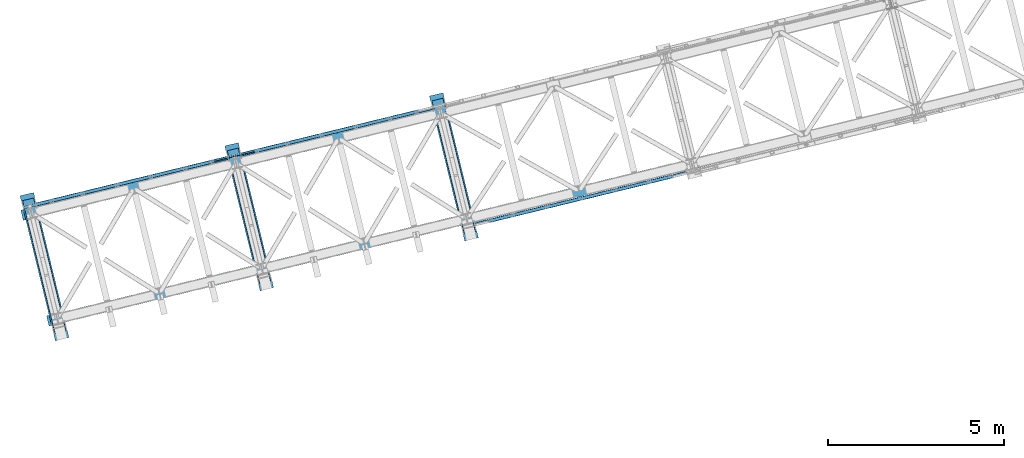
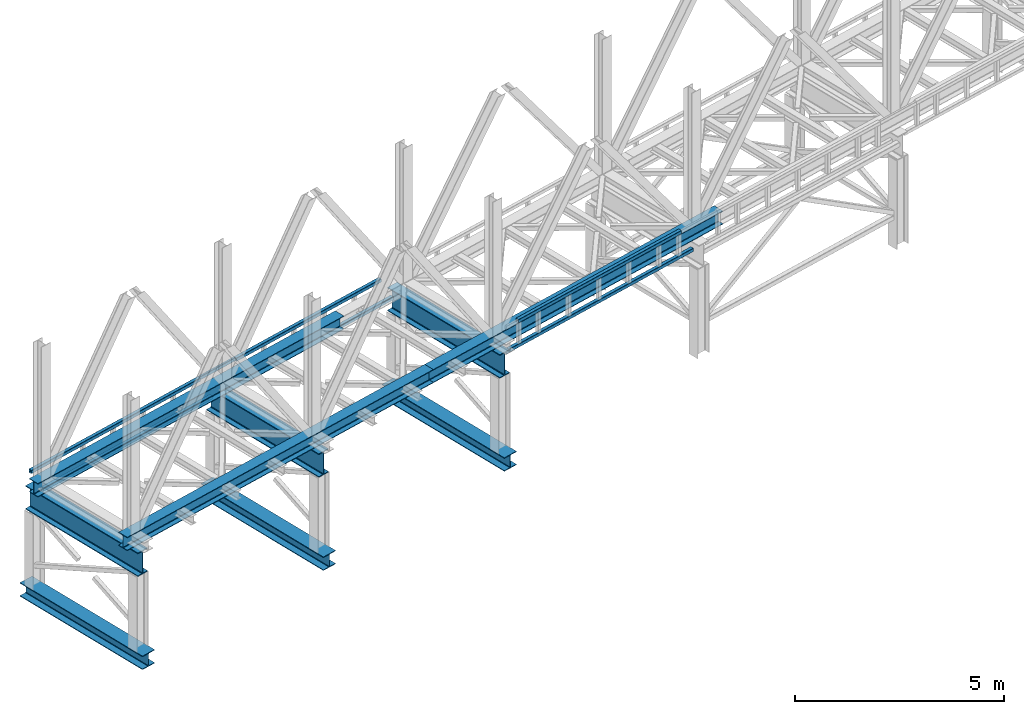
# One storey, part 15 of 93: 16 beams.
"""IFC4 building model written with IfcOpenShell, lengths in millimetres."""

from ifc_helpers import new_model, entity, si_unit, converted_unit, derived_unit, direction, frame, origin, place, context, subcontext, project, spatial, indexed_curve, outline, extrude, material, type_object, element, save


model = new_model("IFC4")

# Units and contexts
model_context = context("Model", 3, precision=0.01, world=origin(), true_north=direction((6.12303176911189e-17, 1.0)))
plan_context = context("Plan", 3, precision=0.01, world=origin(), true_north=direction((6.12303176911189e-17, 1.0)))
body_context = subcontext(model_context, "Body", "Model", "MODEL_VIEW")
ifc_project = project(units=[si_unit("LENGTHUNIT", "METRE", prefix="MILLI"), si_unit("AREAUNIT", "SQUARE_METRE"), si_unit("VOLUMEUNIT", "CUBIC_METRE"), converted_unit("PLANEANGLEUNIT", "DEGREE", entity("IfcRatioMeasure", 0.0174532925199433), si_unit("PLANEANGLEUNIT", "RADIAN"), dimensions=[0, 0, 0, 0, 0, 0, 0]), si_unit("MASSUNIT", "GRAM", prefix="KILO"), derived_unit("MASSDENSITYUNIT", [(si_unit("MASSUNIT", "GRAM", prefix="KILO"), 1), (si_unit("LENGTHUNIT", "METRE"), -3)]), derived_unit("MOMENTOFINERTIAUNIT", [(si_unit("LENGTHUNIT", "METRE"), 4)]), si_unit("TIMEUNIT", "SECOND"), si_unit("FREQUENCYUNIT", "HERTZ"), si_unit("THERMODYNAMICTEMPERATUREUNIT", "DEGREE_CELSIUS"), derived_unit("THERMALTRANSMITTANCEUNIT", [(si_unit("MASSUNIT", "GRAM", prefix="KILO"), 1), (si_unit("THERMODYNAMICTEMPERATUREUNIT", "KELVIN"), -1), (si_unit("TIMEUNIT", "SECOND"), -3)]), derived_unit("VOLUMETRICFLOWRATEUNIT", [(si_unit("LENGTHUNIT", "METRE"), 3), (si_unit("TIMEUNIT", "SECOND"), -1)]), derived_unit("MASSFLOWRATEUNIT", [(si_unit("MASSUNIT", "GRAM", prefix="KILO"), 1), (si_unit("TIMEUNIT", "SECOND"), -1)]), derived_unit("ROTATIONALFREQUENCYUNIT", [(si_unit("TIMEUNIT", "SECOND"), -1)]), si_unit("ELECTRICCURRENTUNIT", "AMPERE"), si_unit("ELECTRICVOLTAGEUNIT", "VOLT"), si_unit("POWERUNIT", "WATT"), si_unit("FORCEUNIT", "NEWTON", prefix="KILO"), si_unit("ILLUMINANCEUNIT", "LUX"), si_unit("LUMINOUSFLUXUNIT", "LUMEN"), si_unit("LUMINOUSINTENSITYUNIT", "CANDELA"), derived_unit("USERDEFINED", [(si_unit("MASSUNIT", "GRAM", prefix="KILO"), -1), (si_unit("LENGTHUNIT", "METRE"), -2), (si_unit("TIMEUNIT", "SECOND"), 3), (si_unit("LUMINOUSFLUXUNIT", "LUMEN"), 1)]), derived_unit("LINEARVELOCITYUNIT", [(si_unit("LENGTHUNIT", "METRE"), 1), (si_unit("TIMEUNIT", "SECOND"), -1)]), si_unit("PRESSUREUNIT", "PASCAL"), derived_unit("USERDEFINED", [(si_unit("LENGTHUNIT", "METRE"), -2), (si_unit("MASSUNIT", "GRAM", prefix="KILO"), 1), (si_unit("TIMEUNIT", "SECOND"), -2)]), derived_unit("LINEARFORCEUNIT", [(si_unit("MASSUNIT", "GRAM", prefix="KILO"), 1), (si_unit("LENGTHUNIT", "METRE"), 1), (si_unit("TIMEUNIT", "SECOND"), -2), (si_unit("LENGTHUNIT", "METRE"), -1)]), derived_unit("PLANARFORCEUNIT", [(si_unit("MASSUNIT", "GRAM", prefix="KILO"), 1), (si_unit("LENGTHUNIT", "METRE"), 1), (si_unit("TIMEUNIT", "SECOND"), -2), (si_unit("LENGTHUNIT", "METRE"), -2)])], contexts=[model_context, plan_context])

# Site, building, storey
site_placement = place(None, origin())
site = spatial("IfcSite", under=ifc_project, at=site_placement, CompositionType="ELEMENT")
building_placement = place(site_placement, origin())
building = spatial("IfcBuilding", under=site, at=building_placement, CompositionType="ELEMENT")
storey_placement = place(building_placement, frame((0.0, 0.0, 15900.0)))
storey = spatial("IfcBuildingStorey", under=building, at=storey_placement, CompositionType="ELEMENT", Elevation=15900.0)

# Beams
ifc_material = material(Name="Metal painted (White)")
beam_type = type_object("IfcBeamType", PredefinedType="BEAM")
beam_1_placement = place(storey_placement, origin())
element("IfcBeam", 1, at=beam_1_placement, inside=storey, type_object=beam_type, material=ifc_material, ObjectType="Steel Beam", PredefinedType="BEAM", context=body_context, shape_type="SweptSolid", body=[
    extrude(outline(indexed_curve([(-199.999999999998, -200.000000000009), (-180.0, -200.000000000009), (-180.0, -28.500000000011), (-178.325349715245, -20.0809644879738), (-173.556349186101, -12.9436508139005), (-166.419035512029, -8.17465028475953), (-157.999999999999, -6.50000000000747), (158.000000000001, -6.50000000000747), (166.419035512033, -8.17465028475953), (173.556349186107, -12.9436508139005), (178.325349715251, -20.0809644879738), (180.000000000002, -28.500000000011), (180.000000000002, -200.000000000009), (200.0, -200.000000000009), (200.0, 199.999999999991), (180.000000000002, 199.999999999991), (180.000000000002, 28.4999999999932), (178.325349715247, 20.0809644879561), (173.556349186107, 12.9436508138827), (166.419035512033, 8.1746502847418), (158.000000000001, 6.49999999998974), (-157.999999999999, 6.49999999999861), (-166.419035512029, 8.17465028475066), (-173.556349186101, 12.9436508139005), (-178.325349715245, 20.080964487965), (-179.999999999998, 28.5000000000021), (-180.0, 199.999999999991), (-199.999999999998, 199.999999999991), (-199.999999999998, -200.000000000009)], self_intersect=False)), frame((-60133.5481539839, 2325.81989631517, 198.0), z_axis=(-0.236826092990339, 0.971552058141473, 0.0), x_axis=(0.0, 0.0, 1.0)), (0.0, 0.0, 1.0), 4250.00000000001),
])
beam_2_placement = place(storey_placement, origin())
element("IfcBeam", 2, at=beam_2_placement, inside=storey, type_object=beam_type, material=ifc_material, ObjectType="Steel Beam", PredefinedType="BEAM", context=body_context, shape_type="SweptSolid", body=[
    extrude(outline(indexed_curve([(-345.500000000002, -160.000000000002), (-322.5, -160.000000000002), (-322.5, -37.4999999999994), (-320.216385975338, -26.0194970290429), (-313.713203435595, -16.2867965644056), (-303.980502970953, -9.78361402465815), (-292.499999999998, -7.49999999999633), (292.500000000001, -7.49999999999633), (303.980502970953, -9.78361402465815), (313.713203435597, -16.2867965644056), (320.21638597534, -26.0194970290429), (322.5, -37.4999999999994), (322.5, -160.000000000002), (345.499999999997, -160.000000000002), (345.499999999997, 160.000000000002), (322.5, 160.000000000002), (322.5, 37.4999999999994), (320.21638597534, 26.0194970290429), (313.713203435597, 16.2867965644056), (303.980502970953, 9.78361402465815), (292.500000000001, 7.49999999999633), (-292.499999999998, 7.50000000000526), (-303.980502970953, 9.78361402466708), (-313.713203435595, 16.2867965644056), (-320.216385975338, 26.0194970290429), (-322.5, 37.4999999999994), (-322.5, 160.000000000002), (-345.500000000002, 160.000000000002), (-345.500000000002, -160.000000000002)], self_intersect=False)), frame((-60180.913372582, 2520.13030794346, 2947.5), z_axis=(-0.236826092990334, 0.971552058141474, 0.0), x_axis=(0.0, 0.0, 1.0)), (0.0, 0.0, 1.0), 3899.99999999999),
])
beam_3_placement = place(storey_placement, origin())
element("IfcBeam", 3, at=beam_3_placement, inside=storey, type_object=beam_type, material=ifc_material, ObjectType="Steel Beam", PredefinedType="BEAM", context=body_context, shape_type="SweptSolid", body=[
    extrude(outline(indexed_curve([(-199.999999999998, -200.0), (-180.0, -200.0), (-180.0, -28.5000000000021), (-178.325349715245, -20.080964487965), (-173.556349186101, -12.9436508138917), (-166.419035512029, -8.17465028475066), (-157.999999999999, -6.49999999999867), (158.000000000001, -6.49999999999867), (166.419035512033, -8.17465028475066), (173.556349186107, -12.9436508138917), (178.325349715251, -20.080964487965), (180.000000000002, -28.5000000000021), (180.000000000002, -200.0), (200.0, -200.0), (200.0, 200.0), (180.000000000002, 200.0), (180.000000000002, 28.5000000000021), (178.325349715247, 20.080964487965), (173.556349186107, 12.9436508138917), (166.419035512033, 8.17465028475066), (158.000000000001, 6.49999999999854), (-157.999999999999, 6.50000000000747), (-166.419035512029, 8.17465028475959), (-173.556349186101, 12.9436508139094), (-178.325349715245, 20.0809644879738), (-179.999999999998, 28.500000000011), (-180.0, 200.0), (-199.999999999998, 200.0), (-199.999999999998, -200.0)], self_intersect=False)), frame((-54304.2358051351, 3746.77645425719, 198.0), z_axis=(-0.236826092990342, 0.971552058141472, 0.0), x_axis=(0.0, 0.0, 1.0)), (0.0, 0.0, 1.0), 4250.0),
])
beam_4_placement = place(storey_placement, origin())
element("IfcBeam", 4, at=beam_4_placement, inside=storey, type_object=beam_type, material=ifc_material, ObjectType="Steel Beam", PredefinedType="BEAM", context=body_context, shape_type="SweptSolid", body=[
    extrude(outline(indexed_curve([(-345.500000000002, -159.999999999993), (-322.5, -159.999999999993), (-322.5, -37.4999999999906), (-320.216385975338, -26.0194970290341), (-313.713203435595, -16.2867965643968), (-303.980502970953, -9.78361402464935), (-292.499999999998, -7.4999999999874), (292.500000000001, -7.4999999999874), (303.980502970953, -9.78361402464935), (313.713203435597, -16.2867965643968), (320.21638597534, -26.0194970290341), (322.5, -37.4999999999906), (322.5, -159.999999999993), (345.499999999997, -159.999999999993), (345.499999999997, 160.000000000011), (322.5, 160.000000000011), (322.5, 37.5000000000083), (320.21638597534, 26.0194970290519), (313.713203435597, 16.2867965644145), (303.980502970953, 9.78361402466708), (292.500000000001, 7.50000000000526), (-292.499999999998, 7.50000000001406), (-303.980502970953, 9.78361402466708), (-313.713203435595, 16.2867965644145), (-320.216385975338, 26.0194970290519), (-322.5, 37.5000000000083), (-322.5, 160.000000000011), (-345.500000000002, 160.000000000011), (-345.500000000002, -159.999999999993)], self_intersect=False)), frame((-54351.6010237331, 3941.08686588548, 2947.5), z_axis=(-0.236826092990334, 0.971552058141474, 0.0), x_axis=(0.0, 0.0, 1.0)), (0.0, 0.0, 1.0), 3899.99999999999),
])
beam_5_placement = place(storey_placement, origin())
element("IfcBeam", 5, at=beam_5_placement, inside=storey, type_object=beam_type, material=ifc_material, ObjectType="Steel Beam", PredefinedType="BEAM", context=body_context, shape_type="SweptSolid", body=[
    extrude(outline(indexed_curve([(-199.999999999998, -199.999999999992), (-180.0, -199.999999999992), (-180.0, -28.4999999999933), (-178.325349715245, -20.0809644879649), (-173.556349186101, -12.9436508138917), (-166.419035512029, -8.17465028474173), (-157.999999999999, -6.49999999999867), (158.000000000001, -6.49999999999867), (166.419035512033, -8.17465028474173), (173.556349186107, -12.9436508138917), (178.325349715251, -20.0809644879649), (180.000000000002, -28.4999999999933), (180.000000000002, -199.999999999992), (200.0, -199.999999999992), (200.0, 200.000000000009), (180.000000000002, 200.000000000009), (180.000000000002, 28.5000000000022), (178.325349715247, 20.0809644879738), (173.556349186107, 12.9436508139006), (166.419035512033, 8.17465028475959), (158.000000000001, 6.5000000000076), (-157.999999999999, 6.50000000001628), (-166.419035512029, 8.17465028476852), (-173.556349186101, 12.9436508139095), (-178.325349715245, 20.0809644879828), (-179.999999999998, 28.5000000000198), (-180.0, 200.000000000009), (-199.999999999998, 200.000000000009), (-199.999999999998, -199.999999999992)], self_intersect=False)), frame((-48474.9234562862, 5167.73301219921, 198.0), z_axis=(-0.236826092990345, 0.971552058141471, 0.0), x_axis=(0.0, 0.0, 1.0)), (0.0, 0.0, 1.0), 4250.00000000001),
])
beam_6_placement = place(storey_placement, origin())
element("IfcBeam", 6, at=beam_6_placement, inside=storey, type_object=beam_type, material=ifc_material, ObjectType="Steel Beam", PredefinedType="BEAM", context=body_context, shape_type="SweptSolid", body=[
    extrude(outline(indexed_curve([(-345.500000000002, -160.00000000001), (-322.5, -160.00000000001), (-322.5, -37.5000000000082), (-320.216385975338, -26.0194970290607), (-313.713203435595, -16.2867965644145), (-303.980502970953, -9.78361402467601), (-292.499999999998, -7.50000000000526), (292.500000000001, -7.50000000000526), (303.980502970953, -9.78361402467601), (313.713203435597, -16.2867965644145), (320.21638597534, -26.0194970290607), (322.5, -37.5000000000082), (322.5, -160.00000000001), (345.499999999997, -160.00000000001), (345.499999999997, 159.999999999993), (322.5, 159.999999999993), (322.5, 37.4999999999906), (320.21638597534, 26.0194970290341), (313.713203435597, 16.2867965643967), (303.980502970953, 9.78361402464922), (292.500000000001, 7.4999999999874), (-292.499999999998, 7.49999999999633), (-303.980502970953, 9.78361402465815), (-313.713203435595, 16.2867965643967), (-320.216385975338, 26.0194970290431), (-322.5, 37.4999999999906), (-322.5, 159.999999999993), (-345.500000000002, 159.999999999993), (-345.500000000002, -160.00000000001)], self_intersect=False)), frame((-48522.2886748843, 5362.0434238275, 2947.5), z_axis=(-0.23682609299033, 0.971552058141475, 0.0), x_axis=(0.0, 0.0, 1.0)), (0.0, 0.0, 1.0), 3899.99999999999),
])
beam_7_placement = place(storey_placement, origin())
element("IfcBeam", 7, at=beam_7_placement, inside=storey, type_object=beam_type, material=ifc_material, ObjectType="Steel Beam", PredefinedType="BEAM", context=body_context, shape_type="SweptSolid", body=[
    extrude(outline(indexed_curve([(-195.999999999999, -150.000000000005), (-179.999999999996, -150.000000000005), (-179.999999999996, -27.7500000000052), (-178.325349715245, -19.3309644879708), (-173.556349186101, -12.1936508139001), (-166.419035512029, -7.42465028475701), (-157.999999999997, -5.75000000000373), (158.000000000005, -5.75000000000373), (166.419035512033, -7.42465028475701), (173.556349186107, -12.1936508139001), (178.325349715251, -19.3309644879708), (180.0, -27.7500000000052), (180.0, -150.000000000005), (196.000000000005, -150.000000000005), (196.000000000005, 149.999999999996), (180.0, 149.999999999996), (180.0, 27.7499999999967), (178.325349715251, 19.3309644879629), (173.556349186107, 12.1936508138912), (166.419035512033, 7.42465028474807), (158.000000000005, 5.74999999999531), (-157.999999999997, 5.74999999999689), (-166.419035512029, 7.42465028474965), (-173.556349186101, 12.1936508138933), (-178.325349715245, 19.3309644879639), (-179.999999999996, 27.7499999999973), (-179.999999999996, 149.999999999999), (-195.999999999999, 149.999999999996), (-195.999999999999, -150.000000000005)], self_intersect=False)), frame((-60542.820625767, 2843.62395562771, 3489.0), z_axis=(0.971552058141477, 0.236826092990323, 0.0), x_axis=(0.0, 0.0, 1.0)), (0.0, 0.0, 1.0), 10150.0),
])
beam_8_placement = place(storey_placement, origin())
element("IfcBeam", 8, at=beam_8_placement, inside=storey, type_object=beam_type, material=ifc_material, ObjectType="Steel Beam", PredefinedType="BEAM", context=body_context, shape_type="SweptSolid", body=[
    extrude(outline(indexed_curve([(-195.999999999999, -150.000000000001), (-179.999999999996, -150.000000000001), (-179.999999999996, -27.750000000002), (-178.325349715245, -19.330964487966), (-173.556349186101, -12.1936508138954), (-166.419035512029, -7.4246502847528), (-157.999999999997, -5.75000000000005), (158.000000000005, -5.75000000000005), (166.419035512033, -7.4246502847528), (173.556349186107, -12.1936508138954), (178.325349715251, -19.330964487966), (180.0, -27.750000000002), (180.0, -150.000000000001), (196.000000000005, -150.000000000001), (196.000000000005, 150.000000000001), (180.0, 150.000000000001), (180.0, 27.750000000002), (178.325349715251, 19.330964487966), (173.556349186107, 12.1936508138954), (166.419035512033, 7.42465028475175), (158.000000000005, 5.75000000000005), (-157.999999999997, 5.75000000000005), (-166.419035512029, 7.4246502847528), (-173.556349186101, 12.1936508138965), (-178.325349715245, 19.3309644879681), (-179.999999999996, 27.750000000002), (-179.999999999996, 150.000000000001), (-195.999999999999, 150.000000000001), (-195.999999999999, -150.000000000001)], self_intersect=False)), frame((-50681.5672356311, 5247.40879947962, 3489.0), z_axis=(0.971552058141476, 0.236826092990324, 0.0), x_axis=(0.0, 0.0, 1.0)), (0.0, 0.0, 1.0), 9600.0),
])
beam_9_placement = place(storey_placement, origin())
element("IfcBeam", 9, at=beam_9_placement, inside=storey, type_object=beam_type, material=ifc_material, ObjectType="Steel Beam", PredefinedType="BEAM", context=body_context, shape_type="SweptSolid", body=[
    extrude(outline(indexed_curve([(-195.999999999999, -150.0), (-179.999999999996, -150.0), (-179.999999999996, -27.7499999999988), (-178.325349715245, -19.330964487965), (-173.556349186101, -12.1936508138944), (-166.419035512029, -7.4246502847507), (-157.999999999997, -5.74999999999794), (158.000000000005, -5.74999999999794), (166.419035512033, -7.4246502847507), (173.556349186107, -12.1936508138944), (178.325349715251, -19.330964487965), (180.0, -27.7499999999988), (180.0, -150.0), (196.000000000005, -150.0), (196.000000000005, 150.000000000003), (180.0, 150.000000000003), (180.0, 27.7500000000031), (178.325349715251, 19.3309644879681), (173.556349186107, 12.1936508138986), (166.419035512033, 7.42465028475491), (158.000000000005, 5.75000000000215), (-157.999999999997, 5.7500000000032), (-166.419035512029, 7.42465028475491), (-173.556349186101, 12.1936508138996), (-178.325349715247, 19.3309644879681), (-179.999999999996, 27.7500000000031), (-179.999999999996, 150.000000000003), (-195.999999999999, 150.000000000003), (-195.999999999999, -150.0)], self_intersect=False)), frame((-61276.981514037, 5855.43533586627, 3489.0), z_axis=(0.971552058141477, 0.23682609299032, 0.0), x_axis=(0.0, 0.0, 1.0)), (0.0, 0.0, 1.0), 10150.0),
])
beam_10_placement = place(storey_placement, origin())
element("IfcBeam", 10, at=beam_10_placement, inside=storey, type_object=beam_type, material=ifc_material, ObjectType="Steel Beam", PredefinedType="BEAM", context=body_context, shape_type="SweptSolid", body=[
    extrude(outline(indexed_curve([(29.4768951153388, -56.8428769007951), (33.3787015556623, -56.8428769007951), (36.9835006656957, -55.3497202197886), (39.7424944585247, -52.5907264269583), (41.2356511395302, -48.9859273169241), (56.8428769008066, 29.4768951153362), (56.8428769008059, 33.3787015556666), (55.3497202197987, 36.9835006656969), (52.5907264269695, 39.7424944585246), (48.9859273169341, 41.2356511395347), (-29.4768951153272, 56.8428769008105), (-33.3787015556515, 56.8428769008063), (-36.9835006656859, 55.3497202197999), (-39.7424944585131, 52.5907264269737), (-41.2356511395192, 48.9859273169308), (-56.8428769007946, -29.4768951153297), (-56.8428769007963, -33.3787015556508), (-55.349720219789, -36.9835006656856), (-52.5907264269576, -39.7424944585136), (-48.9859273169225, -41.2356511395193), (29.4768951153388, -56.8428769007951)], self_intersect=False), holes=[indexed_curve([(-50.9634988887029, -25.5484203233846), (-37.3071763475863, 43.1065493048366), (-35.8140196665766, 46.7113484148699), (-33.0550258737478, 49.4703422077047), (-29.4502267637124, 50.9634988887108), (-25.548420323392, 50.9634988887114), (43.1065493048361, 37.3071763475952), (46.7113484148701, 35.8140196665898), (49.4703422076984, 33.0550258737623), (50.963498888707, 29.4502267637229), (50.9634988887104, 25.5484203234008), (37.3071763475958, -43.1065493048208), (35.8140196665845, -46.7113484148627), (33.0550258737576, -49.4703422076934), (29.4502267637232, -50.9634988886997), (25.5484203234048, -50.9634988887007), (-43.1065493048284, -37.3071763475835), (-46.7113484148604, -35.8140196665785), (-49.4703422076917, -33.0550258737504), (-50.9634988887022, -29.450226763715), (-50.9634988887029, -25.5484203233846)], self_intersect=False)]), frame((-61247.5941200419, 6068.4550088408, 3830.0), z_axis=(0.971552058141251, 0.23682609299125, 0.0), x_axis=(0.232275546020893, -0.95288395777052, -0.195090322015947)), (0.0, 0.0, 1.0), 5595.99999999999),
])
beam_11_placement = place(storey_placement, origin())
element("IfcBeam", 11, at=beam_11_placement, inside=storey, type_object=beam_type, material=ifc_material, ObjectType="Steel Beam", PredefinedType="BEAM", context=body_context, shape_type="SweptSolid", body=[
    extrude(outline(indexed_curve([(29.4768951153018, -56.8428769008144), (33.3787015556258, -56.8428769008144), (36.9835006656596, -55.3497202198119), (39.7424944584905, -52.590726426981), (41.2356511394979, -48.9859273169476), (56.842876900814, 29.4768951153048), (56.8428769008189, 33.3787015556257), (55.3497202198128, 36.9835006656636), (52.590726426984, 39.7424944584929), (48.9859273169497, 41.2356511395006), (-29.4768951153031, 56.8428769008191), (-33.3787015556266, 56.8428769008212), (-36.9835006656618, 55.3497202198168), (-39.7424944584927, 52.5907264269859), (-41.2356511395002, 48.9859273169525), (-56.8428769008193, -29.4768951152993), (-56.8428769008191, -33.3787015556212), (-55.3497202198151, -36.9835006656587), (-52.5907264269859, -39.742494458486), (-48.985927316952, -41.2356511394957), (29.4768951153018, -56.8428769008144)], self_intersect=False), holes=[indexed_curve([(-50.963498888721, -25.5484203233671), (-37.3071763475673, 43.1065493048556), (-35.8140196665578, 46.7113484148885), (-33.0550258737259, 49.4703422077192), (-29.4502267636906, 50.9634988887236), (-25.5484203233702, 50.9634988887221), (43.1065493048524, 37.3071763475682), (46.7113484148847, 35.8140196665609), (49.4703422077155, 33.0550258737312), (50.9634988887216, 29.4502267636933), (50.9634988887187, 25.548420323372), (37.3071763475661, -43.1065493048509), (35.8140196665545, -46.7113484148834), (33.055025873724, -49.4703422077122), (29.4502267636888, -50.9634988887166), (25.5484203233694, -50.9634988887153), (-43.1065493048538, -37.3071763475591), (-46.711348414883, -35.8140196665524), (-49.4703422077128, -33.0550258737229), (-50.9634988887218, -29.4502267636888), (-50.963498888721, -25.5484203233671)], self_intersect=False)]), frame((-60866.7457132505, 6161.29083729302, 3118.0), z_axis=(0.971552058141251, 0.23682609299125, 0.0), x_axis=(-0.232275546020868, 0.952883957770417, 0.195090322016481)), (0.0, 0.0, 1.0), 5603.99999999999),
])
beam_12_placement = place(storey_placement, origin())
element("IfcBeam", 12, at=beam_12_placement, inside=storey, type_object=beam_type, material=ifc_material, ObjectType="Steel Beam", PredefinedType="BEAM", context=body_context, shape_type="SweptSolid", body=[
    extrude(outline(indexed_curve([(29.4768951153008, -56.8428769008142), (33.3787015556247, -56.8428769008142), (36.9835006656585, -55.3497202198117), (39.7424944584895, -52.5907264269808), (41.2356511394969, -48.9859273169474), (56.842876900813, 29.476895115305), (56.8428769008179, 33.3787015556259), (55.3497202198118, 36.9835006656638), (52.590726426983, 39.7424944584932), (48.9859273169487, 41.2356511395008), (-29.4768951153041, 56.8428769008193), (-33.3787015556276, 56.8428769008214), (-36.9835006656628, 55.349720219817), (-39.7424944584938, 52.5907264269861), (-41.2356511395012, 48.9859273169527), (-56.8428769008204, -29.4768951152991), (-56.8428769008201, -33.378701555621), (-55.3497202198161, -36.9835006656585), (-52.5907264269869, -39.7424944584858), (-48.985927316952, -41.2356511394957), (29.4768951153008, -56.8428769008142)], self_intersect=False), holes=[indexed_curve([(-50.9634988887189, -25.5484203233675), (-37.3071763475663, 43.1065493048554), (-35.8140196665568, 46.7113484148883), (-33.0550258737259, 49.4703422077192), (-29.4502267636906, 50.9634988887236), (-25.5484203233702, 50.9634988887221), (43.1065493048514, 37.3071763475684), (46.7113484148847, 35.8140196665609), (49.4703422077155, 33.0550258737312), (50.9634988887226, 29.450226763693), (50.9634988887208, 25.5484203233716), (37.3071763475671, -43.1065493048511), (35.8140196665545, -46.7113484148834), (33.0550258737261, -49.4703422077126), (29.4502267636888, -50.9634988887166), (25.5484203233684, -50.9634988887151), (-43.1065493048518, -37.3071763475595), (-46.711348414883, -35.8140196665524), (-49.4703422077128, -33.0550258737229), (-50.9634988887197, -29.4502267636892), (-50.9634988887189, -25.5484203233675)], self_intersect=False)]), frame((-55033.5471561691, 7583.194699607, 3118.0), z_axis=(0.971552058141251, 0.23682609299125, 0.0), x_axis=(-0.232275546020868, 0.952883957770417, 0.195090322016481)), (0.0, 0.0, 1.0), 5600.00000000001),
])
beam_13_placement = place(storey_placement, origin())
element("IfcBeam", 13, at=beam_13_placement, inside=storey, type_object=beam_type, material=ifc_material, ObjectType="Steel Beam", PredefinedType="BEAM", context=body_context, shape_type="SweptSolid", body=[
    extrude(outline(indexed_curve([(29.4768951153378, -56.8428769007949), (33.3787015556613, -56.8428769007949), (36.9835006656947, -55.3497202197884), (39.7424944585237, -52.5907264269581), (41.2356511395291, -48.9859273169239), (56.8428769008073, 29.4768951153449), (56.8428769008049, 33.3787015556668), (55.3497202197977, 36.9835006656971), (52.5907264269684, 39.7424944585248), (48.9859273169331, 41.2356511395349), (-29.4768951153282, 56.8428769008107), (-33.3787015556525, 56.8428769008065), (-36.983500665687, 55.3497202198001), (-39.7424944585141, 52.5907264269739), (-41.2356511395206, 48.9859273169399), (-56.8428769007957, -29.4768951153295), (-56.8428769007974, -33.3787015556506), (-55.34972021979, -36.9835006656854), (-52.5907264269587, -39.7424944585134), (-48.9859273169235, -41.2356511395191), (29.4768951153378, -56.8428769007949)], self_intersect=False), holes=[indexed_curve([(-50.9634988887029, -25.5484203233846), (-37.3071763475873, 43.1065493048368), (-35.8140196665787, 46.7113484148704), (-33.0550258737499, 49.4703422077051), (-29.4502267637124, 50.9634988887108), (-25.548420323393, 50.9634988887117), (43.1065493048361, 37.3071763475952), (46.711348414866, 35.8140196665906), (49.4703422076974, 33.0550258737625), (50.963498888707, 29.4502267637229), (50.9634988887094, 25.548420323401), (37.3071763475958, -43.1065493048208), (35.8140196665835, -46.7113484148625), (33.0550258737566, -49.4703422076932), (29.4502267637221, -50.9634988886995), (25.5484203234017, -50.9634988887001), (-43.1065493048284, -37.3071763475835), (-46.7113484148614, -35.8140196665783), (-49.4703422076938, -33.05502587375), (-50.9634988887022, -29.450226763715), (-50.9634988887029, -25.5484203233846)], self_intersect=False)]), frame((-54644.9263329125, 7677.92513680314, 3830.0), z_axis=(0.971552058141251, 0.23682609299125, 0.0), x_axis=(0.232275546020893, -0.95288395777052, -0.195090322015947)), (0.0, 0.0, 1.0), 4799.99999999999),
])
beam_14_placement = place(storey_placement, origin())
element("IfcBeam", 14, at=beam_14_placement, inside=storey, type_object=beam_type, material=ifc_material, ObjectType="Steel Beam", PredefinedType="BEAM", context=body_context, shape_type="SweptSolid", body=[
    extrude(outline(indexed_curve([(9.86118950714915, -52.9410704605091), (13.7629959474743, -52.9410704605091), (17.3677950575112, -51.4479137795148), (20.126788850346, -48.6889199866861), (21.6199455313573, -45.0841208766548), (37.2271712928046, 33.3787015555715), (37.2271712928149, 37.2805079958926), (35.7340146118143, 40.8853071059309), (32.97502081899, 43.6443008987647), (29.370221708959, 45.1374575797825), (-9.86118950715515, 52.9410704605059), (-13.7629959474785, 52.9410704605099), (-17.3677950575151, 51.4479137795112), (-20.1267888503512, 48.6889199866871), (-21.6199455313625, 45.0841208766558), (-37.2271712928098, -33.3787015555705), (-37.227171292819, -37.2805079958918), (-35.7340146118193, -40.8853071059343), (-32.9750208189972, -43.6443008987633), (-29.370221708965, -45.1374575797857), (9.86118950714915, -52.9410704605091)], self_intersect=False), holes=[indexed_curve([(-31.347793280705, -29.4502267636479), (-17.6914707394412, 39.2047428645529), (-16.1983140584258, 42.8095419745834), (-13.4393202655939, 45.5685357674083), (-9.83452115555316, 47.0616924484062), (-5.9327147152307, 47.0616924483979), (23.4908436968534, 41.2089827878556), (27.0956428068832, 39.7158261068425), (29.8546365997095, 36.9568323140083), (31.3477932807091, 33.3520332039702), (31.347793280702, 29.4502267636485), (17.6914707394371, -39.204742864552), (16.1983140584197, -42.8095419745821), (13.4393202655828, -45.5685357674105), (9.83452115554697, -47.0616924484049), (5.9327147152276, -47.0616924483973), (-23.4908436968606, -41.2089827878542), (-27.0956428068904, -39.7158261068411), (-29.8546365997137, -36.9568323140075), (-31.3477932807122, -33.3520332039696), (-31.347793280705, -29.4502267636479)], self_intersect=False)]), frame((-55815.5253245421, 7413.16486637756, 3830.0), z_axis=(0.971552058141243, 0.236826092991282, 0.0), x_axis=(-0.232275546020792, 0.952883957770107, 0.195090322018083)), (0.0, 0.0, 1.0), 1200.0),
])
beam_15_placement = place(storey_placement, origin())
element("IfcBeam", 15, at=beam_15_placement, inside=storey, type_object=beam_type, material=ifc_material, ObjectType="Steel Beam", PredefinedType="BEAM", context=body_context, shape_type="SweptSolid", body=[
    extrude(outline(indexed_curve([(29.4768951153272, -56.8428769008016), (33.3787015556497, -56.8428769008016), (36.9835006656846, -55.3497202197933), (39.7424944585133, -52.5907264269652), (41.23565113952, -48.9859273169314), (56.8428769007987, 29.4768951153285), (56.842876900798, 33.3787015556523), (55.3497202197922, 36.9835006656891), (52.5907264269616, 39.742494458515), (48.9859273169276, 41.2356511395206), (-29.4768951153358, 56.8428769008011), (-33.3787015556583, 56.8428769008011), (-36.9835006656924, 55.349720219797), (-39.7424944585189, 52.5907264269641), (-41.235651139526, 48.9859273169281), (-56.8428769008057, -29.4768951153315), (-56.8428769008046, -33.3787015556532), (-55.349720219798, -36.9835006656858), (-52.5907264269683, -39.7424944585159), (-48.9859273169342, -41.2356511395215), (29.4768951153272, -56.8428769008016)], self_intersect=False), holes=[indexed_curve([(-50.9634988887062, -25.548420323397), (-37.3071763475882, 43.1065493048327), (-35.8140196665846, 46.7113484148672), (-33.055025873755, 49.4703422076995), (-29.4502267637201, 50.9634988887078), (-25.5484203233946, 50.9634988887072), (43.1065493048316, 37.3071763475877), (46.7113484148708, 35.814019666581), (49.4703422076995, 33.0550258737511), (50.9634988887042, 29.4502267637145), (50.9634988887054, 25.5484203233928), (37.3071763475853, -43.1065493048366), (35.8140196665786, -46.7113484148704), (33.0550258737485, -49.4703422077004), (29.4502267637144, -50.9634988887044), (25.5484203233919, -50.9634988887045), (-43.1065493048343, -37.3071763475849), (-46.7113484148714, -35.8140196665787), (-49.4703422077005, -33.0550258737509), (-50.9634988887051, -29.4502267637187), (-50.9634988887062, -25.548420323397)], self_intersect=False)]), frame((-48373.2120470171, 5594.9750855306, 3118.0), z_axis=(0.97155205814122, 0.236826092991375, 0.0), x_axis=(-0.232275546020954, 0.952883957770495, 0.195090322015999)), (0.0, 0.0, 1.0), 6199.99999999998),
])
beam_16_placement = place(storey_placement, origin())
element("IfcBeam", 16, at=beam_16_placement, inside=storey, type_object=beam_type, material=ifc_material, ObjectType="Steel Beam", PredefinedType="BEAM", context=body_context, shape_type="SweptSolid", body=[
    extrude(outline(indexed_curve([(29.4768951153305, -56.8428769007956), (33.378701555653, -56.8428769007956), (36.9835006656875, -55.3497202197894), (39.7424944585167, -52.5907264269593), (41.2356511395223, -48.9859273169252), (56.842876900802, 29.4768951153345), (56.8428769008026, 33.3787015556647), (55.3497202197956, 36.9835006656951), (52.5907264269654, 39.7424944585231), (48.9859273169322, 41.235651139533), (-29.4768951153282, 56.8428769008128), (-33.3787015556525, 56.8428769008088), (-36.9835006656871, 55.3497202198026), (-39.7424944585143, 52.5907264269765), (-41.2356511395227, 48.9859273169341), (-56.8428769008024, -29.4768951153256), (-56.8428769008013, -33.3787015556473), (-55.3497202197951, -36.9835006656819), (-52.5907264269649, -39.7424944585099), (-48.9859273169299, -41.2356511395158), (29.4768951153305, -56.8428769007956)], self_intersect=False), holes=[indexed_curve([(-50.9634988887043, -25.548420323382), (-37.3071763475849, 43.1065493048387), (-35.8140196665772, 46.7113484148724), (-33.0550258737493, 49.4703422077072), (-29.4502267637147, 50.9634988887134), (-25.5484203233923, 50.9634988887134), (43.1065493048329, 37.307176347594), (46.711348414871, 35.8140196665876), (49.4703422076991, 33.05502587376), (50.9634988887065, 29.4502267637207), (50.9634988887077, 25.548420323399), (37.3071763475893, -43.1065493048219), (35.814019666582, -46.7113484148645), (33.0550258737518, -49.4703422076944), (29.4502267637173, -50.9634988887006), (25.5484203233938, -50.9634988887004), (-43.1065493048324, -37.3071763475809), (-46.7113484148695, -35.8140196665746), (-49.4703422076986, -33.0550258737468), (-50.9634988887059, -29.450226763712), (-50.9634988887043, -25.548420323382)], self_intersect=False)]), frame((-47984.5912237606, 5689.70552272673, 3830.0), z_axis=(0.97155205814122, 0.236826092991375, 0.0), x_axis=(0.232275546020954, -0.952883957770495, -0.195090322015999)), (0.0, 0.0, 1.0), 5400.00000000001),
])

save(model, "model.ifc")
